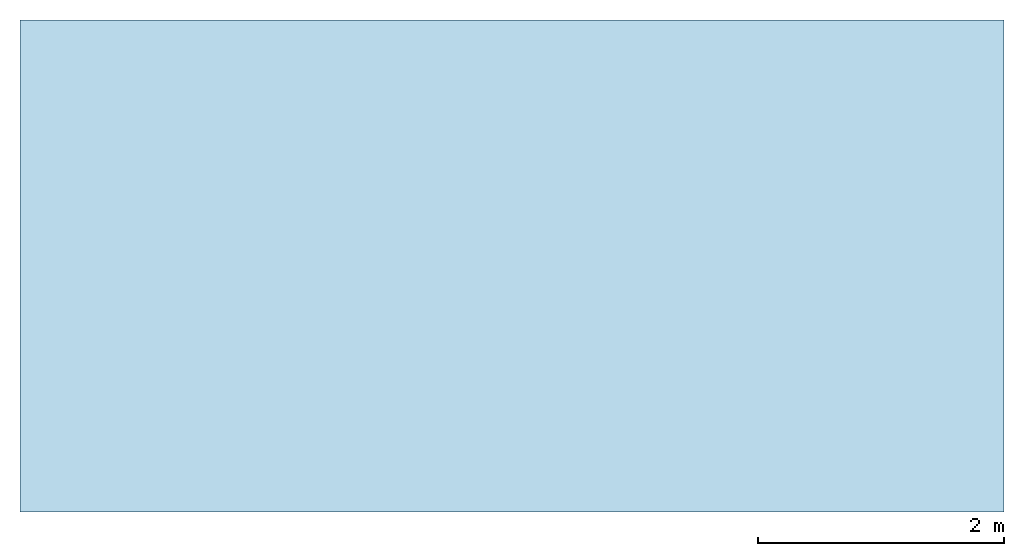
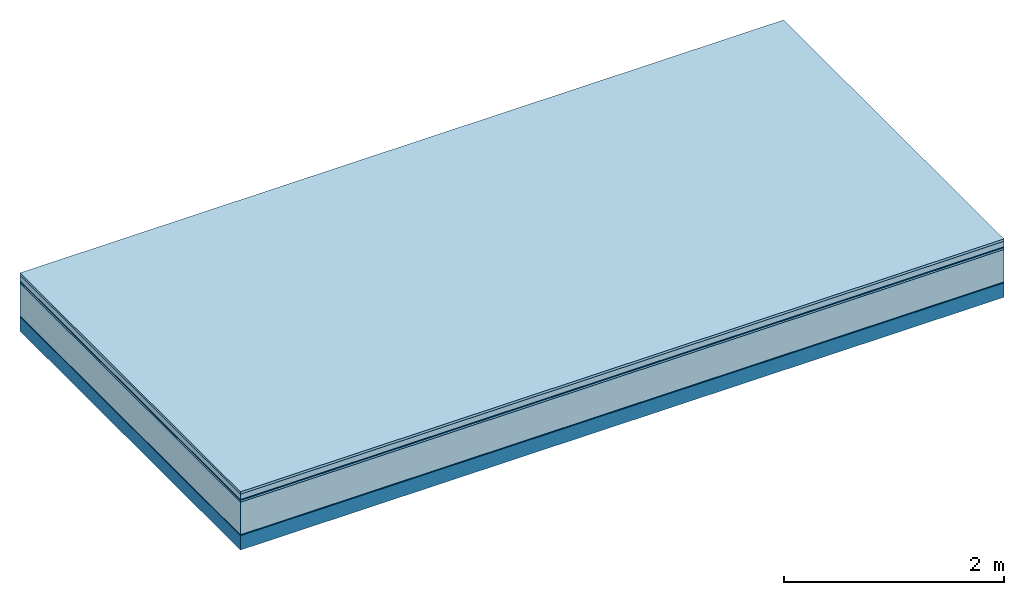
# One storey: 6 plates, 1 member, 1 element without a shape of its own.
"""IFC4 building model written with IfcOpenShell, lengths in metres."""

from ifc_helpers import new_model, si_unit, derived_unit, direction, frame, frame_2d, origin, origin_with_axes, place, context, project, spatial, rectangle, extrude, material, layer, layer_set, type_object, element, aggregate, save


model = new_model("IFC4")

# Units and contexts
plan_context = context("Plan", 3, precision=1e-05, world=origin(), true_north=direction((0.0, 1.0)))
model_context = context("Model", 3, precision=1e-05, world=origin(), true_north=direction((0.0, 1.0)))
ifc_project = project(units=[si_unit("LENGTHUNIT", "METRE"), derived_unit("SOUNDPRESSUREUNIT", [(si_unit("PRESSUREUNIT", "PASCAL", prefix="MICRO"), 0)]), si_unit("ENERGYUNIT", "JOULE", prefix="MEGA"), si_unit("MASSUNIT", "GRAM", prefix="KILO"), derived_unit("THERMALTRANSMITTANCEUNIT", [(si_unit("POWERUNIT", "WATT"), 1), (si_unit("AREAUNIT", "SQUARE_METRE"), -1), (si_unit("THERMODYNAMICTEMPERATUREUNIT", "KELVIN"), -1)]), derived_unit("AREADENSITYUNIT", [(si_unit("MASSUNIT", "GRAM", prefix="KILO"), 1), (si_unit("AREAUNIT", "SQUARE_METRE"), -1)]), derived_unit("USERDEFINED", [(si_unit("ENERGYUNIT", "JOULE", prefix="MEGA"), 1), (si_unit("AREAUNIT", "SQUARE_METRE"), -1)])], contexts=[plan_context, model_context])

# Site, building, storey
site = spatial("IfcSite", under=ifc_project)
building_placement = place(None, origin())
building = spatial("IfcBuilding", under=site, at=building_placement)
storey_placement = place(building_placement, origin())
storey = spatial("IfcBuildingStorey", under=building, at=storey_placement)

# Slab, member, plates
ifc_material_1 = material(Category="07.009")
ifc_layer_1 = layer(ifc_material_1, 0.026, Name="Use and protection layer 3")
ifc_material_2 = material(Category="07.011")
ifc_layer_2 = layer(ifc_material_2, 0.06, Name="Use and protection layer 2")
ifc_material_3 = material(Name="Protective layer + Fire protection cover RF1", Category="09.007")
ifc_layer_3 = layer(ifc_material_3, 0.01, Name="Use and protection layer 1")
ifc_material_4 = material(Name="Bituminous", Category="09.003")
ifc_layer_4 = layer(ifc_material_4, 0.02, Name="Seal")
ifc_material_5 = material(Name="Mineral wool", Category="10.008")
ifc_layer_5 = layer(ifc_material_5, 0.36, Name="Exterior insulation layer 1")
ifc_material_6 = material(Name="Vapor-permeable barrier", Category="09.006")
ifc_layer_6 = layer(ifc_material_6, 0.01, Name="layer / temporary roof")
ifc_material_7 = material(Name="no composite action")
ifc_layer_7 = layer(ifc_material_7, 0.0, Name="Bond")
ifc_layer_8 = layer(None, 0.16, Name="Support")
ifc_layer_set = layer_set([ifc_layer_1, ifc_layer_2, ifc_layer_3, ifc_layer_4, ifc_layer_5, ifc_layer_6, ifc_layer_7, ifc_layer_8])
slab_type = type_object("IfcSlabType", Name="F0047", PredefinedType="NOTDEFINED", material=ifc_layer_set)
slab_placement = place(None, frame((0.0, 0.0, 0.0), z_axis=(0.0, 0.0, -1.0), x_axis=(1.0, 0.0, 0.0)))
slab = element("IfcSlab", 1, at=slab_placement, inside=storey, type_object=slab_type, material=ifc_layer_set, Name="Slab #1")
ifc_material_8 = material(Name="Solid timber panel")
member_placement = place(slab_placement, origin())
member = element("IfcMember", 2, at=member_placement, material=ifc_material_8, Name="Support", context=plan_context, shape_type="SweptSolid", body=[
    extrude(rectangle(XDim=1.0, YDim=0.16, at=frame_2d((0.5, 0.08), x_axis=(1.0, 0.0))), frame((0.0, 4.0, 0.486), z_axis=(0.0, -1.0, 0.0), x_axis=(1.0, 0.0, 0.0)), (0.0, 0.0, 1.0), 4.0),
    extrude(rectangle(XDim=1.0, YDim=0.16, at=frame_2d((0.5, 0.08), x_axis=(1.0, 0.0))), frame((1.0, 4.0, 0.486), z_axis=(0.0, -1.0, 0.0), x_axis=(1.0, 0.0, 0.0)), (0.0, 0.0, 1.0), 4.0),
    extrude(rectangle(XDim=1.0, YDim=0.16, at=frame_2d((0.5, 0.08), x_axis=(1.0, 0.0))), frame((2.0, 4.0, 0.486), z_axis=(0.0, -1.0, 0.0), x_axis=(1.0, 0.0, 0.0)), (0.0, 0.0, 1.0), 4.0),
    extrude(rectangle(XDim=1.0, YDim=0.16, at=frame_2d((0.5, 0.08), x_axis=(1.0, 0.0))), frame((3.0, 4.0, 0.486), z_axis=(0.0, -1.0, 0.0), x_axis=(1.0, 0.0, 0.0)), (0.0, 0.0, 1.0), 4.0),
    extrude(rectangle(XDim=1.0, YDim=0.16, at=frame_2d((0.5, 0.08), x_axis=(1.0, 0.0))), frame((4.0, 4.0, 0.486), z_axis=(0.0, -1.0, 0.0), x_axis=(1.0, 0.0, 0.0)), (0.0, 0.0, 1.0), 4.0),
    extrude(rectangle(XDim=1.0, YDim=0.16, at=frame_2d((0.5, 0.08), x_axis=(1.0, 0.0))), frame((5.0, 4.0, 0.486), z_axis=(0.0, -1.0, 0.0), x_axis=(1.0, 0.0, 0.0)), (0.0, 0.0, 1.0), 4.0),
    extrude(rectangle(XDim=1.0, YDim=0.16, at=frame_2d((0.5, 0.08), x_axis=(1.0, 0.0))), frame((6.0, 4.0, 0.486), z_axis=(0.0, -1.0, 0.0), x_axis=(1.0, 0.0, 0.0)), (0.0, 0.0, 1.0), 4.0),
    extrude(rectangle(XDim=1.0, YDim=0.16, at=frame_2d((0.5, 0.08), x_axis=(1.0, 0.0))), frame((7.0, 4.0, 0.486), z_axis=(0.0, -1.0, 0.0), x_axis=(1.0, 0.0, 0.0)), (0.0, 0.0, 1.0), 4.0),
])
plate_1_placement = place(slab_placement, origin())
plate_1 = element("IfcPlate", 3, at=plate_1_placement, material=ifc_material_1, Name="Use and protection layer 3", context=plan_context, shape_type="SweptSolid", body=[
    extrude(rectangle(XDim=8.0, YDim=4.0, at=frame_2d((4.0, 2.0), x_axis=(1.0, 0.0))), origin_with_axes(), (0.0, 0.0, 1.0), 0.026),
])
plate_2_placement = place(slab_placement, origin())
plate_2 = element("IfcPlate", 4, at=plate_2_placement, material=ifc_material_2, Name="Use and protection layer 2", context=plan_context, shape_type="SweptSolid", body=[
    extrude(rectangle(XDim=8.0, YDim=4.0, at=frame_2d((4.0, 2.0), x_axis=(1.0, 0.0))), frame((0.0, 0.0, 0.026), z_axis=(0.0, 0.0, 1.0), x_axis=(1.0, 0.0, 0.0)), (0.0, 0.0, 1.0), 0.06),
])
plate_3_placement = place(slab_placement, origin())
plate_3 = element("IfcPlate", 5, at=plate_3_placement, material=ifc_material_3, Name="Use and protection layer 1", context=plan_context, shape_type="SweptSolid", body=[
    extrude(rectangle(XDim=8.0, YDim=4.0, at=frame_2d((4.0, 2.0), x_axis=(1.0, 0.0))), frame((0.0, 0.0, 0.086), z_axis=(0.0, 0.0, 1.0), x_axis=(1.0, 0.0, 0.0)), (0.0, 0.0, 1.0), 0.01),
])
plate_4_placement = place(slab_placement, origin())
plate_4 = element("IfcPlate", 6, at=plate_4_placement, material=ifc_material_4, Name="Seal", context=plan_context, shape_type="SweptSolid", body=[
    extrude(rectangle(XDim=8.0, YDim=4.0, at=frame_2d((4.0, 2.0), x_axis=(1.0, 0.0))), frame((0.0, 0.0, 0.096), z_axis=(0.0, 0.0, 1.0), x_axis=(1.0, 0.0, 0.0)), (0.0, 0.0, 1.0), 0.02),
])
plate_5_placement = place(slab_placement, origin())
plate_5 = element("IfcPlate", 7, at=plate_5_placement, material=ifc_material_5, Name="Exterior insulation layer 1", context=plan_context, shape_type="SweptSolid", body=[
    extrude(rectangle(XDim=8.0, YDim=4.0, at=frame_2d((4.0, 2.0), x_axis=(1.0, 0.0))), frame((0.0, 0.0, 0.116), z_axis=(0.0, 0.0, 1.0), x_axis=(1.0, 0.0, 0.0)), (0.0, 0.0, 1.0), 0.36),
])
plate_6_placement = place(slab_placement, origin())
plate_6 = element("IfcPlate", 8, at=plate_6_placement, material=ifc_material_6, Name="layer / temporary roof", context=plan_context, shape_type="SweptSolid", body=[
    extrude(rectangle(XDim=8.0, YDim=4.0, at=frame_2d((4.0, 2.0), x_axis=(1.0, 0.0))), frame((0.0, 0.0, 0.476), z_axis=(0.0, 0.0, 1.0), x_axis=(1.0, 0.0, 0.0)), (0.0, 0.0, 1.0), 0.01),
])
aggregate(slab, [plate_1, plate_2, plate_3, plate_4, plate_5, plate_6, member])

save(model, "model.ifc")
